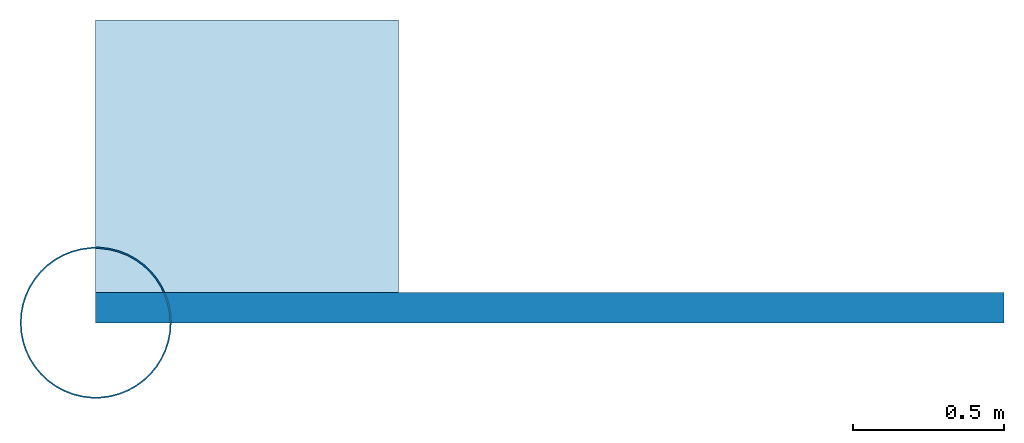
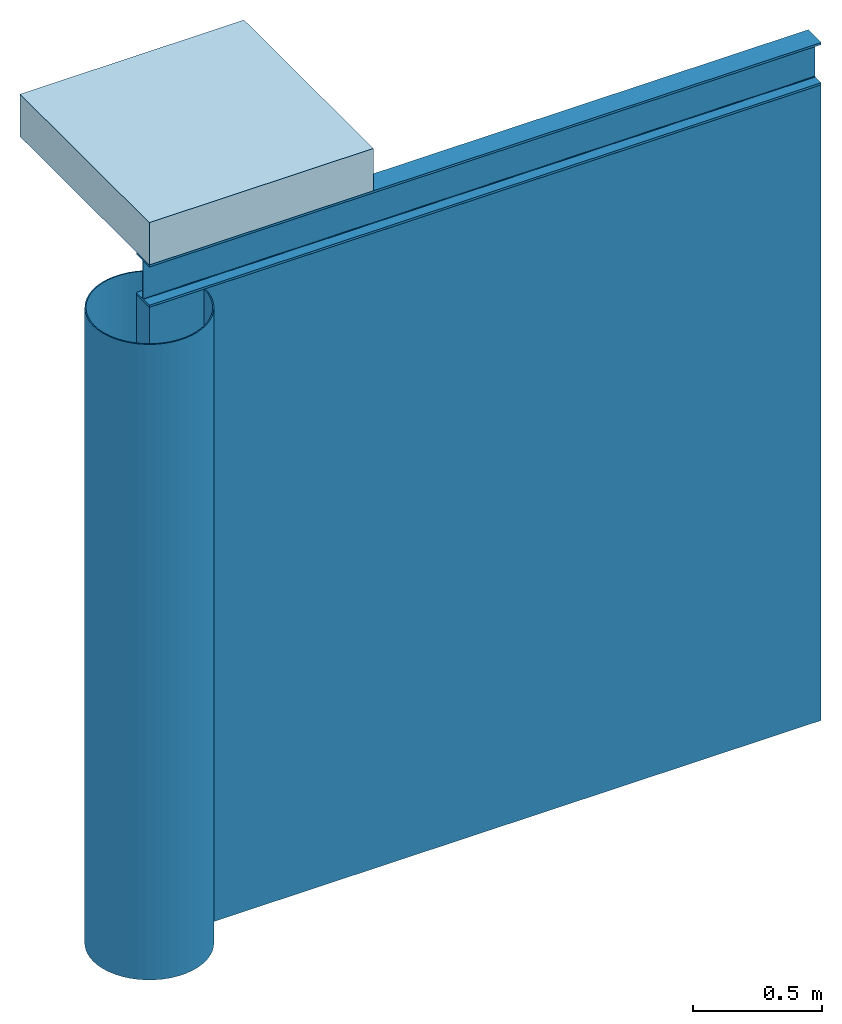
# One storey: 1 beam, 1 column, 1 slab, 1 wall.
"""IFC4 building model written with IfcOpenShell, lengths in metres."""

from ifc_helpers import new_model, entity, si_unit, converted_unit, frame, origin_with_axes, origin_2d_with_axis, place, context, subcontext, project, spatial, indexed_curve, hollow_circle, i_section, outline, extrude, material, layer, layer_set, layer_usage, material_profile, profile_set, profile_usage, type_object, element, save


model = new_model("IFC4")

# Units and contexts
model_context = context("Model", 3, precision=1e-05, world=origin_with_axes())
plan_context = context("Plan", 2, precision=1e-05, world=origin_2d_with_axis())
body_context = subcontext(model_context, "Body", "Model", "MODEL_VIEW")
ifc_project = project(units=[si_unit("AREAUNIT", "SQUARE_METRE"), si_unit("VOLUMEUNIT", "CUBIC_METRE"), si_unit("LENGTHUNIT", "METRE"), converted_unit("PLANEANGLEUNIT", "degree", entity("IfcReal", 0.0174532925199433), si_unit("PLANEANGLEUNIT", "RADIAN"), dimensions=[0, 0, 0, 0, 0, 0, 0])], contexts=[model_context, plan_context])

# Site, building, storey
site_placement = place(None, origin_with_axes())
site = spatial("IfcSite", under=ifc_project, at=site_placement)
building_placement = place(site_placement, origin_with_axes())
building = spatial("IfcBuilding", under=site, at=building_placement, Name="Building")
storey_placement = place(building_placement, origin_with_axes())
storey = spatial("IfcBuildingStorey", under=building, at=storey_placement, Name="Storey")

# Column
ifc_material = material()
ifc_material_profile_1 = material_profile(ifc_material, hollow_circle(Radius=0.25, WallThickness=0.005))
ifc_profile_set_1 = profile_set([ifc_material_profile_1])
ifc_profile_usage_1 = profile_usage(ifc_profile_set_1, cardinal=5)
column_type = type_object("IfcColumnType", Name="C2", PredefinedType="NOTDEFINED", material=ifc_profile_set_1)
column_placement = place(storey_placement, origin_with_axes())
element("IfcColumn", 1, at=column_placement, inside=storey, type_object=column_type, material=ifc_profile_usage_1, Name="Column", PredefinedType="NOTDEFINED", context=body_context, shape_type="SweptSolid", body=[
    extrude(hollow_circle(Radius=0.25, WallThickness=0.005), origin_with_axes(), (0.0, 0.0, 1.0), 3.0),
])

# Beam
ifc_material_profile_2 = material_profile(ifc_material, i_section(OverallWidth=0.1, OverallDepth=0.2, WebThickness=0.005, FlangeThickness=0.01, FilletRadius=0.005))
ifc_profile_set_2 = profile_set([ifc_material_profile_2])
ifc_profile_usage_2 = profile_usage(ifc_profile_set_2, cardinal=5)
beam_type = type_object("IfcBeamType", Name="B1", PredefinedType="NOTDEFINED", material=ifc_profile_set_2)
beam_placement = place(storey_placement, frame((0.0, 0.0499999895691872, 3.09999990463257), z_axis=(1.0, 1.62920699153801e-07, -1.62920684942947e-07), x_axis=(-1.62920684942947e-07, 1.0, 1.19209275339927e-07)))
element("IfcBeam", 2, at=beam_placement, inside=storey, type_object=beam_type, material=ifc_profile_usage_2, Name="Beam", PredefinedType="NOTDEFINED", context=body_context, shape_type="SweptSolid", body=[
    extrude(i_section(OverallWidth=0.1, OverallDepth=0.2, WebThickness=0.005, FlangeThickness=0.01, FilletRadius=0.005), origin_with_axes(), (0.0, 0.0, 1.0), 3.0),
])

# Slab
ifc_layer_1 = layer(ifc_material, 0.2)
ifc_layer_set_1 = layer_set([ifc_layer_1])
ifc_layer_usage_1 = layer_usage(ifc_layer_set_1, "AXIS3", "POSITIVE", 0.0)
slab_type = type_object("IfcSlabType", Name="FLR150", PredefinedType="NOTDEFINED", material=ifc_layer_set_1)
slab_placement = place(storey_placement, frame((2.42143869400024e-08, 4.65661287307739e-07, 3.19999933242798), z_axis=(0.0, 0.0, 1.0), x_axis=(1.0, 0.0, 0.0)))
element("IfcSlab", 3, at=slab_placement, inside=storey, type_object=slab_type, material=ifc_layer_usage_1, Name="Slab", PredefinedType="NOTDEFINED", context=body_context, shape_type="SweptSolid", body=[
    extrude(outline(indexed_curve([(0.0, 0.0), (1.0, 0.0), (1.0, 1.0), (0.0, 1.0), (0.0, 0.0)])), None, (0.0, 0.0, 1.0), 0.2),
])

# Wall
ifc_layer_2 = layer(ifc_material, 0.1)
ifc_layer_set_2 = layer_set([ifc_layer_2])
ifc_layer_usage_2 = layer_usage(ifc_layer_set_2, "AXIS2", "POSITIVE", 0.0)
wall_type = type_object("IfcWallType", Name="WAL100", PredefinedType="NOTDEFINED", material=ifc_layer_set_2)
wall_placement = place(storey_placement, origin_with_axes())
element("IfcWall", 4, at=wall_placement, inside=storey, type_object=wall_type, material=ifc_layer_usage_2, Name="Wall", PredefinedType="NOTDEFINED", context=body_context, shape_type="SweptSolid", body=[
    extrude(outline(indexed_curve([(0.0, 0.0), (0.0, 0.1), (3.0, 0.1), (3.0, 0.0), (0.0, 0.0)], self_intersect=False)), origin_with_axes(), (0.0, 0.0, 1.0), 3.0),
])

save(model, "model.ifc")
